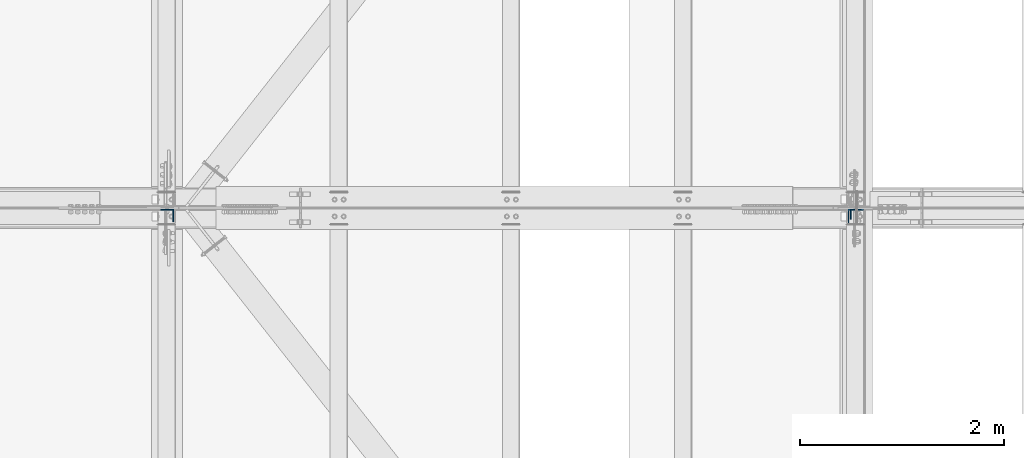
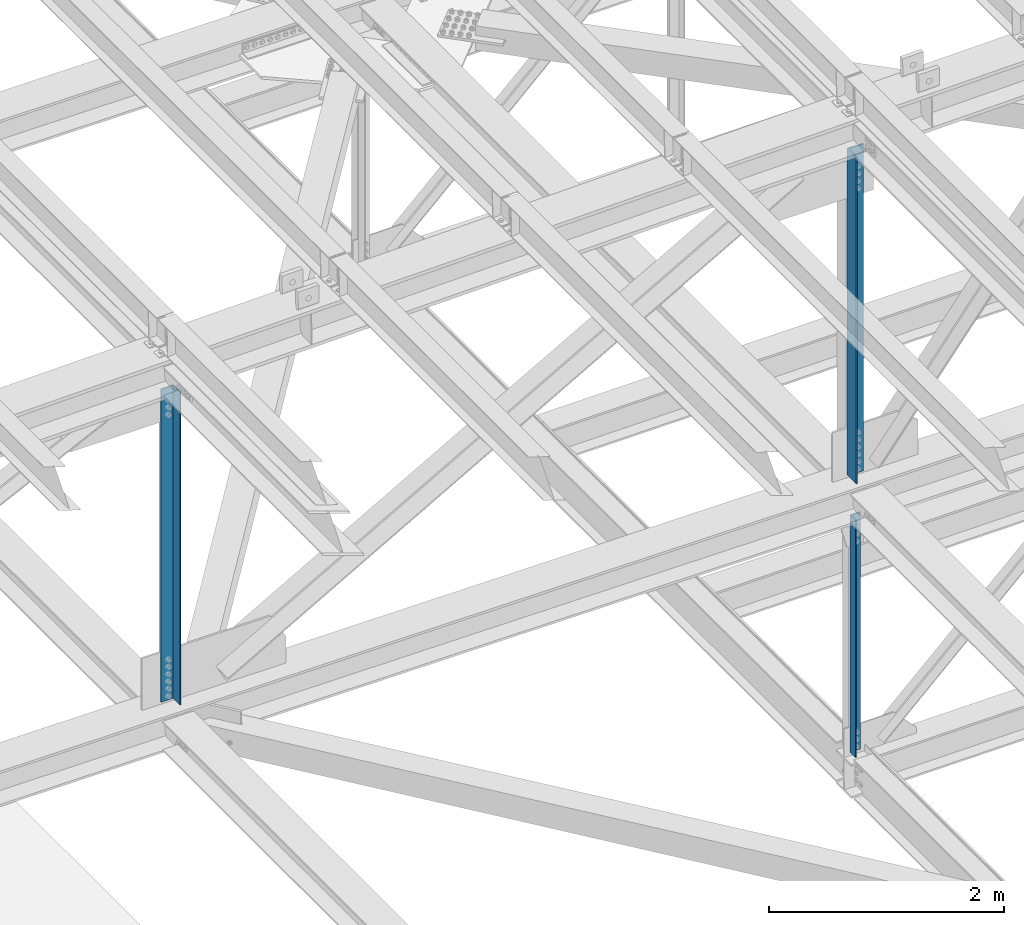
# One storey, part 1337 of 3843: 3 columns, 3 elements without a shape of their own.
"""IFC2X3 building model written with IfcOpenShell, lengths in millimetres."""

from ifc_helpers import new_model, si_unit, frame, origin_with_axes, place, context, subcontext, project, spatial, faceted_brep, material, type_object, element, aggregate, save


model = new_model("IFC2X3")

# Units and contexts
model_context = context("Model", 3, precision=1e-05, world=origin_with_axes())
body_context = subcontext(model_context, "Body", "Model", "MODEL_VIEW")
ifc_project = project(units=[si_unit("LENGTHUNIT", "METRE", prefix="MILLI"), si_unit("AREAUNIT", "SQUARE_METRE"), si_unit("VOLUMEUNIT", "CUBIC_METRE"), si_unit("MASSUNIT", "GRAM", prefix="KILO"), si_unit("TIMEUNIT", "SECOND"), si_unit("PLANEANGLEUNIT", "RADIAN"), si_unit("SOLIDANGLEUNIT", "STERADIAN"), si_unit("THERMODYNAMICTEMPERATUREUNIT", "DEGREE_CELSIUS"), si_unit("LUMINOUSINTENSITYUNIT", "LUMEN")], contexts=[model_context])

# Site, building, storey
site_placement = place(None, origin_with_axes())
site = spatial("IfcSite", under=ifc_project, at=site_placement, CompositionType="ELEMENT")
building_placement = place(site_placement, origin_with_axes())
building = spatial("IfcBuilding", under=site, at=building_placement, Name="Undefined", CompositionType="ELEMENT")
storey_placement = place(building_placement, origin_with_axes())
storey = spatial("IfcBuildingStorey", under=building, at=storey_placement, Name="Undefined", CompositionType="ELEMENT", Elevation=0.0)

# Assembly, column
assembly_1_placement = place(storey_placement, origin_with_axes())
assembly_1 = element("IfcElementAssembly", 1, at=assembly_1_placement, inside=storey, Name="ANGLE", AssemblyPlace="NOTDEFINED", PredefinedType="RIGID_FRAME")
ifc_material = material(Name="STEEL/A572-50")
column_type_1 = type_object("IfcColumnType", Name="L4X4X3/8", PredefinedType="NOTDEFINED")
column_1_placement = place(assembly_1_placement, frame((77012.8, 50498.375, 39447.0226474184), z_axis=(0.0, -1.0, 0.0), x_axis=(0.0, 0.0, 1.0)))
column_1 = element("IfcColumn", 2, at=column_1_placement, type_object=column_type_1, material=ifc_material, Name="ANGLE", ObjectType="L4X4X3/8", context=body_context, shape_type="Brep", body=[
    faceted_brep([(219.203361802072, 50.8000000000029, -50.8000000000029), (219.203361802072, 50.8000000000029, 50.8000000000029), (2681.09933534212, 50.8000000000029, 50.8000000000029), (2681.09933534212, 50.8000000000029, -50.8000000000029), (219.203361802072, 41.2749999999942, 50.8000000000029), (2681.09933534212, 41.2749999999942, 50.8000000000029), (219.203361802072, 41.2749999999942, -41.2750000000015), (2681.09933534212, 41.2749999999942, -41.2750000000015), (219.203361802072, -50.8000000000029, -41.2750000000015), (2681.09933534212, -50.8000000000029, -41.2750000000015), (219.203361802072, -50.8000000000029, -50.8000000000029), (2681.09933534212, -50.8000000000029, -50.8000000000029)], [[[0, 1, 2, 3]], [[1, 4, 5, 2]], [[4, 6, 7, 5]], [[6, 8, 9, 7]], [[8, 10, 11, 9]], [[10, 0, 3, 11]], [[5, 7, 9, 11, 3, 2]], [[10, 8, 6, 4, 1, 0]]]),
])
aggregate(assembly_1, [column_1])

assembly_2_placement = place(storey_placement, origin_with_axes())
assembly_2 = element("IfcElementAssembly", 3, at=assembly_2_placement, inside=storey, Name="ANGLE", AssemblyPlace="NOTDEFINED", PredefinedType="RIGID_FRAME")
column_type_2 = type_object("IfcColumnType", Name="L6X6X1/2", PredefinedType="NOTDEFINED")
column_2_placement = place(assembly_2_placement, frame((77012.7999999724, 50472.975, 42337.741462658), z_axis=(0.0, -1.0, 0.0), x_axis=(0.0, 0.0, 1.0)))
column_2 = element("IfcColumn", 4, at=column_2_placement, type_object=column_type_2, material=ifc_material, Name="ANGLE", ObjectType="L6X6X1/2", context=body_context, shape_type="Brep", body=[
    faceted_brep([(210.384580878504, 76.1999999999971, -76.1999999999971), (210.384580878504, 76.1999999999971, 76.1999999999971), (3606.44414516215, 76.1999999999971, 76.1999999999971), (3606.44414516215, 76.1999999999971, -76.1999999999971), (210.384580878504, 63.5, 76.1999999999971), (3606.44414516215, 63.5, 76.1999999999971), (210.384580878504, 63.5, -63.5), (3606.44414516215, 63.5, -63.5), (210.384580878504, -76.1999999999971, -63.5), (3606.44414516215, -76.1999999999971, -63.5), (210.384580878504, -76.1999999999971, -76.1999999999971), (3606.44414516215, -76.1999999999971, -76.1999999999971)], [[[0, 1, 2, 3]], [[1, 4, 5, 2]], [[4, 6, 7, 5]], [[6, 8, 9, 7]], [[8, 10, 11, 9]], [[10, 0, 3, 11]], [[5, 7, 9, 11, 3, 2]], [[10, 8, 6, 4, 1, 0]]]),
])
aggregate(assembly_2, [column_2])

assembly_3_placement = place(storey_placement, origin_with_axes())
assembly_3 = element("IfcElementAssembly", 5, at=assembly_3_placement, inside=storey, Name="ANGLE", AssemblyPlace="NOTDEFINED", PredefinedType="RIGID_FRAME")
column_type_3 = type_object("IfcColumnType", Name="L5X5X3/8", PredefinedType="NOTDEFINED")
column_3_placement = place(assembly_3_placement, frame((70256.3999973476, 50485.675, 42344.1288700917), z_axis=(-1.0, 0.0, 0.0), x_axis=(0.0, 0.0, 1.0)))
column_3 = element("IfcColumn", 6, at=column_3_placement, type_object=column_type_3, material=ifc_material, Name="ANGLE", ObjectType="L5X5X3/8", context=body_context, shape_type="Brep", body=[
    faceted_brep([(210.885139529346, 63.5, -63.5), (210.885139529346, 63.5, 63.5), (3463.19758272878, 63.5, 63.5), (3463.19758272878, 63.5, -63.5), (210.885139529346, 53.9749999999985, 63.5), (3463.19758272878, 53.9749999999985, 63.5), (210.885139529346, 53.9749999999985, -53.9750000000058), (3463.19758272878, 53.9749999999985, -53.9750000000058), (210.885139529346, -63.5, -53.9750000000058), (3463.19758272878, -63.5, -53.9750000000058), (210.885139529346, -63.5, -63.5), (3463.19758272878, -63.5, -63.5)], [[[0, 1, 2, 3]], [[1, 4, 5, 2]], [[4, 6, 7, 5]], [[6, 8, 9, 7]], [[8, 10, 11, 9]], [[10, 0, 3, 11]], [[5, 7, 9, 11, 3, 2]], [[10, 8, 6, 4, 1, 0]]]),
])
aggregate(assembly_3, [column_3])

save(model, "model.ifc")
